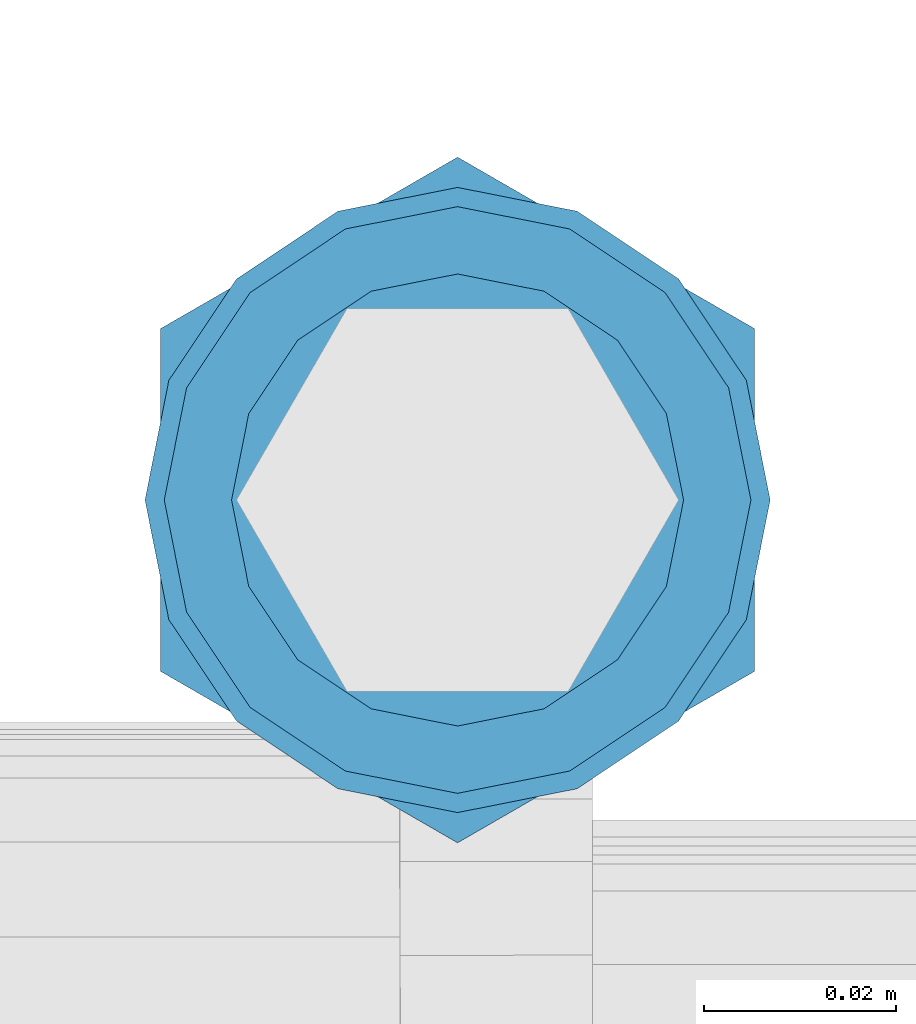
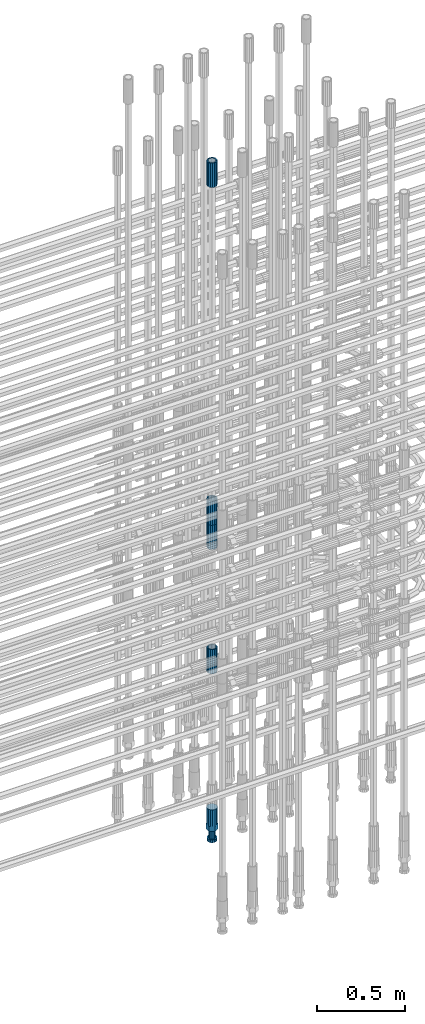
# One storey, part 16 of 119: 5 beams.
"""IFC2X3 building model written with IfcOpenShell, lengths in millimetres."""

from ifc_helpers import new_model, si_unit, frame, origin_with_axes, place, context, subcontext, project, spatial, faceted_brep, material, type_object, element, save


model = new_model("IFC2X3")

# Units and contexts
model_context = context("Model", 3, precision=1e-05, world=origin_with_axes())
body_context = subcontext(model_context, "Body", "Model", "MODEL_VIEW")
ifc_project = project(units=[si_unit("LENGTHUNIT", "METRE", prefix="MILLI"), si_unit("AREAUNIT", "SQUARE_METRE"), si_unit("VOLUMEUNIT", "CUBIC_METRE"), si_unit("MASSUNIT", "GRAM", prefix="KILO"), si_unit("TIMEUNIT", "SECOND"), si_unit("PLANEANGLEUNIT", "RADIAN"), si_unit("SOLIDANGLEUNIT", "STERADIAN"), si_unit("THERMODYNAMICTEMPERATUREUNIT", "DEGREE_CELSIUS"), si_unit("LUMINOUSINTENSITYUNIT", "LUMEN")], contexts=[model_context])

# Site, building, storey
site_placement = place(None, origin_with_axes())
site = spatial("IfcSite", under=ifc_project, at=site_placement, CompositionType="ELEMENT")
building_placement = place(site_placement, origin_with_axes())
building = spatial("IfcBuilding", under=site, at=building_placement, Name="Undefined", CompositionType="ELEMENT")
storey_placement = place(building_placement, origin_with_axes())
storey = spatial("IfcBuildingStorey", under=building, at=storey_placement, Name="Undefined", CompositionType="ELEMENT", Elevation=0.0)

# Beams
ifc_material = material(Name="STEEL/S275")
beam_type_1 = type_object("IfcBeamType", PredefinedType="NOTDEFINED")
beam_1_placement = place(storey_placement, frame((2035125.00611127, 6205269.10830108, 20704.6057291635), z_axis=(1.0, 0.0, 0.0), x_axis=(0.0, 0.0, 1.0)))
element("IfcBeam", 1, at=beam_1_placement, inside=storey, type_object=beam_type_1, material=ifc_material, Name="AG40N", context=body_context, shape_type="Brep", body=[
    faceted_brep([(1.62981450557709e-09, -23.4999999990687, 0.0), (7.45058059692383e-09, -21.7111690142192, 8.99306066057534), (170.000002125278, -21.711168999318, 8.99306066022245), (170.000002127141, -23.4999999844003, -3.66071617463604e-10), (4.65661287307739e-09, -16.6170093587134, 16.6170093578889), (170.000002122484, -16.6170093440451, 16.6170093575288), (1.86264514923096e-09, -8.99306066217832, 21.7111690140277), (170.000002118759, -8.99306064750999, 21.7111690136603), (2.3283064365387e-10, 9.31322574615479e-10, 23.5), (170.000002114102, 1.28056854009628e-08, 23.4999999996485), (-6.51925802230835e-09, 8.99306065868586, 21.7111690140241), (170.00000211224, 8.99306067335419, 21.7111690136639), (-7.45058059692383e-09, 16.6170093561523, 16.6170093578853), (170.000002109446, 16.6170093708206, 16.6170093575324), (-9.31322574615479e-09, 21.711169013055, 8.99306066057534), (170.000002108514, 21.7111690277234, 8.99306066022245), (-1.16415321826935e-09, 23.5000000009313, 0.0), (170.000002108514, 23.5000000144355, -3.66071617463604e-10), (-8.38190317153931e-09, 21.7111690151505, -8.99306066059444), (170.000002110377, 21.7111690300517, -8.9930606609546), (-5.58793544769287e-09, 16.6170093598776, -16.6170093579008), (170.000002113171, 16.6170093745459, -16.6170093582609), (-9.31322574615479e-10, 8.99306066334248, -21.7111690140396), (170.000002115965, 8.99306067801081, -21.7111690143961), (2.3283064365387e-10, 9.31322574615479e-10, -23.5), (170.00000211969, 1.7927959561348e-08, -23.5000000003843), (5.58793544769287e-09, -8.99306065752171, -21.7111690140396), (170.000002123415, -8.99306064285338, -21.7111690143961), (8.38190317153931e-09, -16.6170093549881, -16.6170093579008), (170.000002125278, -16.6170093403198, -16.6170093582646), (9.31322574615479e-09, -21.7111690121237, -8.99306066059444), (170.000002127141, -21.7111689972226, -8.9930606609546), (1.11758708953857e-08, -30.4999999990687, -9.54969436861575e-12), (1.30385160446167e-08, -28.1783257392235, -11.6718446871514), (170.000002129003, -28.1783257243223, -11.6718446875116), (170.000002129935, -30.4999999841675, -3.66071617463604e-10), (1.02445483207703e-08, -21.5667568228673, -21.5667568262129), (170.000002128072, -21.566756808199, -21.5667568265694), (7.45058059692383e-09, -11.6718446831219, -28.1783257416196), (170.000002125278, -11.6718446684536, -28.1783257419834), (3.72529029846191e-09, 3.95812094211578e-09, -30.5000000000277), (170.00000211969, 1.83936208486557e-08, -30.5000000003879), (-9.31322574615479e-10, 11.6718446905725, -28.1783257416232), (170.000002115965, 11.6718447052408, -28.1783257419797), (-6.51925802230835e-09, 21.5667568286881, -21.5667568262093), (170.000002110377, 21.5667568433564, -21.5667568265694), (-9.31322574615479e-09, 28.178325742716, -11.6718446871478), (170.000002108514, 28.1783257573843, -11.6718446875079), (-1.21071934700012e-08, 30.5, -5.91171556152403e-12), (170.000002106652, 30.5000000144355, -3.62433638656512e-10), (-1.21071934700012e-08, 28.1783257401548, 11.6718446871359), (170.00000210572, 28.1783257548232, 11.6718446867794), (-1.02445483207703e-08, 21.5667568240315, 21.5667568261974), (170.000002107583, 21.566756838467, 21.5667568258409), (-7.45058059692383e-09, 11.671844684286, 28.1783257416041), (170.000002110377, 11.6718446989544, 28.178325741244), (-2.79396772384644e-09, -2.56113708019257e-09, 30.5000000000159), (170.000002114102, 1.18743628263474e-08, 30.4999999996558), (1.86264514923096e-09, -11.6718446896411, 28.1783257416114), (170.000002118759, -11.67184467474, 28.178325741244), (7.45058059692383e-09, -21.5667568275239, 21.5667568261974), (170.000002123415, -21.5667568126228, 21.5667568258373), (1.02445483207703e-08, -28.1783257415518, 11.6718446871359), (170.000002127141, -28.1783257271163, 11.6718446867794)], [[[0, 1, 2, 3]], [[1, 4, 5, 2]], [[4, 6, 7, 5]], [[6, 8, 9, 7]], [[8, 10, 11, 9]], [[10, 12, 13, 11]], [[12, 14, 15, 13]], [[14, 16, 17, 15]], [[16, 18, 19, 17]], [[18, 20, 21, 19]], [[20, 22, 23, 21]], [[22, 24, 25, 23]], [[24, 26, 27, 25]], [[26, 28, 29, 27]], [[28, 30, 31, 29]], [[30, 0, 3, 31]], [[32, 33, 34, 35]], [[33, 36, 37, 34]], [[36, 38, 39, 37]], [[38, 40, 41, 39]], [[40, 42, 43, 41]], [[42, 44, 45, 43]], [[44, 46, 47, 45]], [[46, 48, 49, 47]], [[48, 50, 51, 49]], [[50, 52, 53, 51]], [[52, 54, 55, 53]], [[54, 56, 57, 55]], [[56, 58, 59, 57]], [[58, 60, 61, 59]], [[60, 62, 63, 61]], [[62, 32, 35, 63]], [[37, 39, 41, 43, 45, 47, 49, 51, 53, 55, 57, 59, 61, 63, 35, 34], [5, 7, 9, 11, 13, 15, 17, 19, 21, 23, 25, 27, 29, 31, 3, 2]], [[62, 60, 58, 56, 54, 52, 50, 48, 46, 44, 42, 40, 38, 36, 33, 32], [30, 28, 26, 24, 22, 20, 18, 16, 14, 12, 10, 8, 6, 4, 1, 0]]]),
])
beam_2_placement = place(storey_placement, frame((2035125.00611127, 6205269.10830108, 20007.7168583144), z_axis=(-0.99999999999998, 1.98000110685822e-07, 0.0), x_axis=(0.0, 0.0, -1.0)))
element("IfcBeam", 2, at=beam_2_placement, inside=storey, type_object=beam_type_1, material=ifc_material, Name="AG40N", context=body_context, shape_type="Brep", body=[
    faceted_brep([(1.62981450557709e-09, -23.4999999990687, 0.0), (7.45058059692383e-09, -21.7111690142192, 8.99306066057534), (170.000002125278, -21.711168999318, 8.99306066022245), (170.000002127141, -23.4999999844003, -3.66071617463604e-10), (4.65661287307739e-09, -16.6170093587134, 16.6170093578889), (170.000002122484, -16.6170093440451, 16.6170093575288), (1.86264514923096e-09, -8.99306066217832, 21.7111690140277), (170.000002118759, -8.99306064750999, 21.7111690136603), (2.3283064365387e-10, 9.31322574615479e-10, 23.5), (170.000002114102, 1.28056854009628e-08, 23.4999999996485), (-6.51925802230835e-09, 8.99306065868586, 21.7111690140241), (170.00000211224, 8.99306067335419, 21.7111690136639), (-7.45058059692383e-09, 16.6170093561523, 16.6170093578853), (170.000002109446, 16.6170093708206, 16.6170093575324), (-9.31322574615479e-09, 21.711169013055, 8.99306066057534), (170.000002108514, 21.7111690277234, 8.99306066022245), (-1.16415321826935e-09, 23.5000000009313, 0.0), (170.000002108514, 23.5000000144355, -3.66071617463604e-10), (-8.38190317153931e-09, 21.7111690151505, -8.99306066059444), (170.000002110377, 21.7111690300517, -8.9930606609546), (-5.58793544769287e-09, 16.6170093598776, -16.6170093579008), (170.000002113171, 16.6170093745459, -16.6170093582609), (-9.31322574615479e-10, 8.99306066334248, -21.7111690140396), (170.000002115965, 8.99306067801081, -21.7111690143961), (2.3283064365387e-10, 9.31322574615479e-10, -23.5), (170.00000211969, 1.7927959561348e-08, -23.5000000003843), (5.58793544769287e-09, -8.99306065752171, -21.7111690140396), (170.000002123415, -8.99306064285338, -21.7111690143961), (8.38190317153931e-09, -16.6170093549881, -16.6170093579008), (170.000002125278, -16.6170093403198, -16.6170093582646), (9.31322574615479e-09, -21.7111690121237, -8.99306066059444), (170.000002127141, -21.7111689972226, -8.9930606609546), (1.11758708953857e-08, -30.4999999990687, -9.54969436861575e-12), (1.30385160446167e-08, -28.1783257392235, -11.6718446871514), (170.000002129003, -28.1783257243223, -11.6718446875116), (170.000002129935, -30.4999999841675, -3.66071617463604e-10), (1.02445483207703e-08, -21.5667568228673, -21.5667568262129), (170.000002128072, -21.566756808199, -21.5667568265694), (7.45058059692383e-09, -11.6718446831219, -28.1783257416196), (170.000002125278, -11.6718446684536, -28.1783257419834), (3.72529029846191e-09, 3.95812094211578e-09, -30.5000000000277), (170.00000211969, 1.83936208486557e-08, -30.5000000003879), (-9.31322574615479e-10, 11.6718446905725, -28.1783257416232), (170.000002115965, 11.6718447052408, -28.1783257419797), (-6.51925802230835e-09, 21.5667568286881, -21.5667568262093), (170.000002110377, 21.5667568433564, -21.5667568265694), (-9.31322574615479e-09, 28.178325742716, -11.6718446871478), (170.000002108514, 28.1783257573843, -11.6718446875079), (-1.21071934700012e-08, 30.5, -5.91171556152403e-12), (170.000002106652, 30.5000000144355, -3.62433638656512e-10), (-1.21071934700012e-08, 28.1783257401548, 11.6718446871359), (170.00000210572, 28.1783257548232, 11.6718446867794), (-1.02445483207703e-08, 21.5667568240315, 21.5667568261974), (170.000002107583, 21.566756838467, 21.5667568258409), (-7.45058059692383e-09, 11.671844684286, 28.1783257416041), (170.000002110377, 11.6718446989544, 28.178325741244), (-2.79396772384644e-09, -2.56113708019257e-09, 30.5000000000159), (170.000002114102, 1.18743628263474e-08, 30.4999999996558), (1.86264514923096e-09, -11.6718446896411, 28.1783257416114), (170.000002118759, -11.67184467474, 28.178325741244), (7.45058059692383e-09, -21.5667568275239, 21.5667568261974), (170.000002123415, -21.5667568126228, 21.5667568258373), (1.02445483207703e-08, -28.1783257415518, 11.6718446871359), (170.000002127141, -28.1783257271163, 11.6718446867794)], [[[0, 1, 2, 3]], [[1, 4, 5, 2]], [[4, 6, 7, 5]], [[6, 8, 9, 7]], [[8, 10, 11, 9]], [[10, 12, 13, 11]], [[12, 14, 15, 13]], [[14, 16, 17, 15]], [[16, 18, 19, 17]], [[18, 20, 21, 19]], [[20, 22, 23, 21]], [[22, 24, 25, 23]], [[24, 26, 27, 25]], [[26, 28, 29, 27]], [[28, 30, 31, 29]], [[30, 0, 3, 31]], [[32, 33, 34, 35]], [[33, 36, 37, 34]], [[36, 38, 39, 37]], [[38, 40, 41, 39]], [[40, 42, 43, 41]], [[42, 44, 45, 43]], [[44, 46, 47, 45]], [[46, 48, 49, 47]], [[48, 50, 51, 49]], [[50, 52, 53, 51]], [[52, 54, 55, 53]], [[54, 56, 57, 55]], [[56, 58, 59, 57]], [[58, 60, 61, 59]], [[60, 62, 63, 61]], [[62, 32, 35, 63]], [[37, 39, 41, 43, 45, 47, 49, 51, 53, 55, 57, 59, 61, 63, 35, 34], [5, 7, 9, 11, 13, 15, 17, 19, 21, 23, 25, 27, 29, 31, 3, 2]], [[62, 60, 58, 56, 54, 52, 50, 48, 46, 44, 42, 40, 38, 36, 33, 32], [30, 28, 26, 24, 22, 20, 18, 16, 14, 12, 10, 8, 6, 4, 1, 0]]]),
])
beam_3_placement = place(storey_placement, frame((2035125.00611127, 6205269.10830108, 23229.9857291635), z_axis=(1.0, 0.0, 0.0), x_axis=(0.0, 0.0, 1.0)))
element("IfcBeam", 3, at=beam_3_placement, inside=storey, type_object=beam_type_1, material=ifc_material, Name="AG40N", context=body_context, shape_type="Brep", body=[
    faceted_brep([(1.62981450557709e-09, -23.4999999990687, 0.0), (7.45058059692383e-09, -21.7111690142192, 8.99306066057534), (170.000002125278, -21.711168999318, 8.99306066022245), (170.000002127141, -23.4999999844003, -3.66071617463604e-10), (4.65661287307739e-09, -16.6170093587134, 16.6170093578889), (170.000002122484, -16.6170093440451, 16.6170093575288), (1.86264514923096e-09, -8.99306066217832, 21.7111690140277), (170.000002118759, -8.99306064750999, 21.7111690136603), (2.3283064365387e-10, 9.31322574615479e-10, 23.5), (170.000002114102, 1.28056854009628e-08, 23.4999999996485), (-6.51925802230835e-09, 8.99306065868586, 21.7111690140241), (170.00000211224, 8.99306067335419, 21.7111690136639), (-7.45058059692383e-09, 16.6170093561523, 16.6170093578853), (170.000002109446, 16.6170093708206, 16.6170093575324), (-9.31322574615479e-09, 21.711169013055, 8.99306066057534), (170.000002108514, 21.7111690277234, 8.99306066022245), (-1.16415321826935e-09, 23.5000000009313, 0.0), (170.000002108514, 23.5000000144355, -3.66071617463604e-10), (-8.38190317153931e-09, 21.7111690151505, -8.99306066059444), (170.000002110377, 21.7111690300517, -8.9930606609546), (-5.58793544769287e-09, 16.6170093598776, -16.6170093579008), (170.000002113171, 16.6170093745459, -16.6170093582609), (-9.31322574615479e-10, 8.99306066334248, -21.7111690140396), (170.000002115965, 8.99306067801081, -21.7111690143961), (2.3283064365387e-10, 9.31322574615479e-10, -23.5), (170.00000211969, 1.7927959561348e-08, -23.5000000003843), (5.58793544769287e-09, -8.99306065752171, -21.7111690140396), (170.000002123415, -8.99306064285338, -21.7111690143961), (8.38190317153931e-09, -16.6170093549881, -16.6170093579008), (170.000002125278, -16.6170093403198, -16.6170093582646), (9.31322574615479e-09, -21.7111690121237, -8.99306066059444), (170.000002127141, -21.7111689972226, -8.9930606609546), (1.11758708953857e-08, -30.4999999990687, -9.54969436861575e-12), (1.30385160446167e-08, -28.1783257392235, -11.6718446871514), (170.000002129003, -28.1783257243223, -11.6718446875116), (170.000002129935, -30.4999999841675, -3.66071617463604e-10), (1.02445483207703e-08, -21.5667568228673, -21.5667568262129), (170.000002128072, -21.566756808199, -21.5667568265694), (7.45058059692383e-09, -11.6718446831219, -28.1783257416196), (170.000002125278, -11.6718446684536, -28.1783257419834), (3.72529029846191e-09, 3.95812094211578e-09, -30.5000000000277), (170.00000211969, 1.83936208486557e-08, -30.5000000003879), (-9.31322574615479e-10, 11.6718446905725, -28.1783257416232), (170.000002115965, 11.6718447052408, -28.1783257419797), (-6.51925802230835e-09, 21.5667568286881, -21.5667568262093), (170.000002110377, 21.5667568433564, -21.5667568265694), (-9.31322574615479e-09, 28.178325742716, -11.6718446871478), (170.000002108514, 28.1783257573843, -11.6718446875079), (-1.21071934700012e-08, 30.5, -5.91171556152403e-12), (170.000002106652, 30.5000000144355, -3.62433638656512e-10), (-1.21071934700012e-08, 28.1783257401548, 11.6718446871359), (170.00000210572, 28.1783257548232, 11.6718446867794), (-1.02445483207703e-08, 21.5667568240315, 21.5667568261974), (170.000002107583, 21.566756838467, 21.5667568258409), (-7.45058059692383e-09, 11.671844684286, 28.1783257416041), (170.000002110377, 11.6718446989544, 28.178325741244), (-2.79396772384644e-09, -2.56113708019257e-09, 30.5000000000159), (170.000002114102, 1.18743628263474e-08, 30.4999999996558), (1.86264514923096e-09, -11.6718446896411, 28.1783257416114), (170.000002118759, -11.67184467474, 28.178325741244), (7.45058059692383e-09, -21.5667568275239, 21.5667568261974), (170.000002123415, -21.5667568126228, 21.5667568258373), (1.02445483207703e-08, -28.1783257415518, 11.6718446871359), (170.000002127141, -28.1783257271163, 11.6718446867794)], [[[0, 1, 2, 3]], [[1, 4, 5, 2]], [[4, 6, 7, 5]], [[6, 8, 9, 7]], [[8, 10, 11, 9]], [[10, 12, 13, 11]], [[12, 14, 15, 13]], [[14, 16, 17, 15]], [[16, 18, 19, 17]], [[18, 20, 21, 19]], [[20, 22, 23, 21]], [[22, 24, 25, 23]], [[24, 26, 27, 25]], [[26, 28, 29, 27]], [[28, 30, 31, 29]], [[30, 0, 3, 31]], [[32, 33, 34, 35]], [[33, 36, 37, 34]], [[36, 38, 39, 37]], [[38, 40, 41, 39]], [[40, 42, 43, 41]], [[42, 44, 45, 43]], [[44, 46, 47, 45]], [[46, 48, 49, 47]], [[48, 50, 51, 49]], [[50, 52, 53, 51]], [[52, 54, 55, 53]], [[54, 56, 57, 55]], [[56, 58, 59, 57]], [[58, 60, 61, 59]], [[60, 62, 63, 61]], [[62, 32, 35, 63]], [[37, 39, 41, 43, 45, 47, 49, 51, 53, 55, 57, 59, 61, 63, 35, 34], [5, 7, 9, 11, 13, 15, 17, 19, 21, 23, 25, 27, 29, 31, 3, 2]], [[62, 60, 58, 56, 54, 52, 50, 48, 46, 44, 42, 40, 38, 36, 33, 32], [30, 28, 26, 24, 22, 20, 18, 16, 14, 12, 10, 8, 6, 4, 1, 0]]]),
])
beam_4_placement = place(storey_placement, frame((2035125.00611127, 6205269.10830108, 21044.6068583137), z_axis=(-0.99999999999998, 1.98000110685822e-07, 0.0), x_axis=(0.0, 0.0, -1.0)))
element("IfcBeam", 4, at=beam_4_placement, inside=storey, type_object=beam_type_1, material=ifc_material, Name="AG40N", context=body_context, shape_type="Brep", body=[
    faceted_brep([(1.62981450557709e-09, -23.4999999990687, 0.0), (7.45058059692383e-09, -21.7111690142192, 8.99306066057534), (170.000002125278, -21.711168999318, 8.99306066022245), (170.000002127141, -23.4999999844003, -3.66071617463604e-10), (4.65661287307739e-09, -16.6170093587134, 16.6170093578889), (170.000002122484, -16.6170093440451, 16.6170093575288), (1.86264514923096e-09, -8.99306066217832, 21.7111690140277), (170.000002118759, -8.99306064750999, 21.7111690136603), (2.3283064365387e-10, 9.31322574615479e-10, 23.5), (170.000002114102, 1.28056854009628e-08, 23.4999999996485), (-6.51925802230835e-09, 8.99306065868586, 21.7111690140241), (170.00000211224, 8.99306067335419, 21.7111690136639), (-7.45058059692383e-09, 16.6170093561523, 16.6170093578853), (170.000002109446, 16.6170093708206, 16.6170093575324), (-9.31322574615479e-09, 21.711169013055, 8.99306066057534), (170.000002108514, 21.7111690277234, 8.99306066022245), (-1.16415321826935e-09, 23.5000000009313, 0.0), (170.000002108514, 23.5000000144355, -3.66071617463604e-10), (-8.38190317153931e-09, 21.7111690151505, -8.99306066059444), (170.000002110377, 21.7111690300517, -8.9930606609546), (-5.58793544769287e-09, 16.6170093598776, -16.6170093579008), (170.000002113171, 16.6170093745459, -16.6170093582609), (-9.31322574615479e-10, 8.99306066334248, -21.7111690140396), (170.000002115965, 8.99306067801081, -21.7111690143961), (2.3283064365387e-10, 9.31322574615479e-10, -23.5), (170.00000211969, 1.7927959561348e-08, -23.5000000003843), (5.58793544769287e-09, -8.99306065752171, -21.7111690140396), (170.000002123415, -8.99306064285338, -21.7111690143961), (8.38190317153931e-09, -16.6170093549881, -16.6170093579008), (170.000002125278, -16.6170093403198, -16.6170093582646), (9.31322574615479e-09, -21.7111690121237, -8.99306066059444), (170.000002127141, -21.7111689972226, -8.9930606609546), (1.11758708953857e-08, -30.4999999990687, -9.54969436861575e-12), (1.30385160446167e-08, -28.1783257392235, -11.6718446871514), (170.000002129003, -28.1783257243223, -11.6718446875116), (170.000002129935, -30.4999999841675, -3.66071617463604e-10), (1.02445483207703e-08, -21.5667568228673, -21.5667568262129), (170.000002128072, -21.566756808199, -21.5667568265694), (7.45058059692383e-09, -11.6718446831219, -28.1783257416196), (170.000002125278, -11.6718446684536, -28.1783257419834), (3.72529029846191e-09, 3.95812094211578e-09, -30.5000000000277), (170.00000211969, 1.83936208486557e-08, -30.5000000003879), (-9.31322574615479e-10, 11.6718446905725, -28.1783257416232), (170.000002115965, 11.6718447052408, -28.1783257419797), (-6.51925802230835e-09, 21.5667568286881, -21.5667568262093), (170.000002110377, 21.5667568433564, -21.5667568265694), (-9.31322574615479e-09, 28.178325742716, -11.6718446871478), (170.000002108514, 28.1783257573843, -11.6718446875079), (-1.21071934700012e-08, 30.5, -5.91171556152403e-12), (170.000002106652, 30.5000000144355, -3.62433638656512e-10), (-1.21071934700012e-08, 28.1783257401548, 11.6718446871359), (170.00000210572, 28.1783257548232, 11.6718446867794), (-1.02445483207703e-08, 21.5667568240315, 21.5667568261974), (170.000002107583, 21.566756838467, 21.5667568258409), (-7.45058059692383e-09, 11.671844684286, 28.1783257416041), (170.000002110377, 11.6718446989544, 28.178325741244), (-2.79396772384644e-09, -2.56113708019257e-09, 30.5000000000159), (170.000002114102, 1.18743628263474e-08, 30.4999999996558), (1.86264514923096e-09, -11.6718446896411, 28.1783257416114), (170.000002118759, -11.67184467474, 28.178325741244), (7.45058059692383e-09, -21.5667568275239, 21.5667568261974), (170.000002123415, -21.5667568126228, 21.5667568258373), (1.02445483207703e-08, -28.1783257415518, 11.6718446871359), (170.000002127141, -28.1783257271163, 11.6718446867794)], [[[0, 1, 2, 3]], [[1, 4, 5, 2]], [[4, 6, 7, 5]], [[6, 8, 9, 7]], [[8, 10, 11, 9]], [[10, 12, 13, 11]], [[12, 14, 15, 13]], [[14, 16, 17, 15]], [[16, 18, 19, 17]], [[18, 20, 21, 19]], [[20, 22, 23, 21]], [[22, 24, 25, 23]], [[24, 26, 27, 25]], [[26, 28, 29, 27]], [[28, 30, 31, 29]], [[30, 0, 3, 31]], [[32, 33, 34, 35]], [[33, 36, 37, 34]], [[36, 38, 39, 37]], [[38, 40, 41, 39]], [[40, 42, 43, 41]], [[42, 44, 45, 43]], [[44, 46, 47, 45]], [[46, 48, 49, 47]], [[48, 50, 51, 49]], [[50, 52, 53, 51]], [[52, 54, 55, 53]], [[54, 56, 57, 55]], [[56, 58, 59, 57]], [[58, 60, 61, 59]], [[60, 62, 63, 61]], [[62, 32, 35, 63]], [[37, 39, 41, 43, 45, 47, 49, 51, 53, 55, 57, 59, 61, 63, 35, 34], [5, 7, 9, 11, 13, 15, 17, 19, 21, 23, 25, 27, 29, 31, 3, 2]], [[62, 60, 58, 56, 54, 52, 50, 48, 46, 44, 42, 40, 38, 36, 33, 32], [30, 28, 26, 24, 22, 20, 18, 16, 14, 12, 10, 8, 6, 4, 1, 0]]]),
])
beam_type_2 = type_object("IfcBeamType", Name="ROD65", PredefinedType="NOTDEFINED")
beam_5_placement = place(storey_placement, frame((2035125.00611127, 6205269.10830108, 18890.9568583144), z_axis=(-0.99999999999998, 1.98000110685822e-07, 0.0), x_axis=(0.0, 0.0, -1.0)))
element("IfcBeam", 5, at=beam_5_placement, inside=storey, type_object=beam_type_2, material=ifc_material, Name="AGB40", ObjectType="ROD65", context=body_context, shape_type="Brep", body=[
    faceted_brep([(116.999999999069, 17.8249999252148, 30.8738056446964), (116.999999998137, 22.0056957420893, 23.632628078838), (116.999999999069, 12.4372115600854, 30.0260848066173), (116.999999999069, 8.17543111252598, 30.8738056446964), (117.000000000931, -17.8250000746921, 30.8738056446964), (150.200000001118, -17.8250000723638, 30.8738056446964), (150.199999999255, 17.8249999275431, 30.8738056446964), (117.000000000931, -8.17543109622784, 30.8738056446964), (117.000000001863, -22.0056959956419, 23.6326278985034), (117.000000000931, -12.4372115437873, 30.0260848066173), (117.000000001863, -35.6500000746455, -2.18278728425503e-10), (150.200000002049, -35.6500000723172, -2.18278728425503e-10), (117.000000001863, -30.8443149488885, 8.32369080289209), (117.000000001863, -30.8443149488885, -8.32369080355784), (117.000000002794, -32.4999999918509, 0.0), (117.000000000931, -17.8250000746921, -30.873805645133), (150.200000001118, -17.8250000723638, -30.873805645133), (117.000000001863, -22.0056959961075, -23.6326278982269), (117.000000000931, -8.17543109389953, -30.873805645133), (117.000000000931, -12.4372115437873, -30.0260848066173), (116.999999999069, 17.8249999252148, -30.873805645133), (150.199999999255, 17.8249999275431, -30.873805645133), (116.999999999069, 8.17543111019768, -30.873805645133), (116.999999999069, 12.4372115600854, -30.0260848066173), (116.999999998137, 22.005695742555, -23.6326280785652), (116.999999998137, 35.6499999251682, -2.18278728425503e-10), (150.199999998324, 35.6499999277294, -2.18278728425503e-10), (116.999999998137, 30.8443150522653, -8.32369036550881), (116.999999997206, 32.5000000081491, 0.0), (116.999999998137, 30.8443150522653, 8.32369036483942), (1.86264514923096e-09, -22.9809703885112, 22.9809703885621), (1.86264514923096e-09, -30.0260848065373, 12.4372115518672), (117.000000001863, -30.0260847983882, 12.4372115518672), (117.000000001863, -22.9809703803621, 22.9809703885621), (-1.86264514923096e-09, 22.9809703885112, -22.9809703885621), (-1.86264514923096e-09, 30.0260848065373, -12.4372115518672), (116.999999998137, 30.0260848146863, -12.4372115518672), (116.999999998137, 22.9809703966603, -22.9809703885621), (1.86264514923096e-09, -30.0260848065373, -12.4372115518672), (1.86264514923096e-09, -22.9809703885112, -22.9809703885621), (117.000000001863, -22.9809703803621, -22.9809703885621), (117.000000001863, -30.0260847983882, -12.4372115518672), (9.31322574615479e-10, -12.4372115519363, 30.0260848066173), (0.0, 0.0, 32.5), (-9.31322574615479e-10, 12.4372115519363, 30.0260848066173), (-1.86264514923096e-09, 22.9809703885112, 22.9809703885621), (-1.86264514923096e-09, 30.0260848065373, 12.4372115518672), (-2.79396772384644e-09, 32.5, 0.0), (-9.31322574615479e-10, 12.4372115519363, -30.0260848066173), (0.0, 0.0, -32.5), (9.31322574615479e-10, -12.4372115519363, -30.0260848066173), (2.79396772384644e-09, -32.5, 0.0), (116.999999998137, 22.9809703966603, 22.9809703885621), (116.999999998137, 30.0260848146863, 12.4372115518672), (117.0, 8.14907252788544e-09, -32.5), (117.0, 8.14907252788544e-09, 32.5), (150.200000000186, -10.5000000959262, 18.1865334791873), (150.199999999255, -9.59262251853943e-08, 20.9999999997126), (150.199999998324, 10.4999999040738, 18.1865334791873), (150.199999997392, 18.1865333835594, 10.4999999997126), (150.199999997392, 20.9999999040738, -2.87400325760245e-10), (150.199999997392, 18.1865333835594, -10.5000000002874), (150.199999998324, 10.4999999040738, -18.1865334797621), (150.199999999255, -9.59262251853943e-08, -21.0000000002874), (150.200000000186, -10.5000000959262, -18.1865334797621), (150.200000000186, -18.1865335754119, -10.5000000002874), (150.200000001118, -21.0000000959262, -2.87400325760245e-10), (150.200000000186, -18.1865335754119, 10.4999999997126), (210.979999999516, 10.4999999082647, 18.1865334791873), (210.979999999516, -9.17352735996246e-08, 20.9999999997126), (210.979999997653, 18.1865333877504, 10.4999999997126), (210.979999997653, 20.9999999082647, -2.87400325760245e-10), (210.979999997653, 18.1865333877504, -10.5000000002874), (210.979999999516, 10.4999999082647, -18.1865334797621), (210.979999999516, -9.17352735996246e-08, -21.0000000002874), (210.979999999516, -10.5000000917353, -18.1865334797621), (210.980000000447, -18.1865335712209, -10.5000000002874), (210.980000001378, -21.0000000917353, -2.87400325760245e-10), (210.980000000447, -18.1865335712209, 10.4999999997126), (210.979999999516, -10.5000000917353, 18.1865334791873), (211.001368402503, -27.7269939335529, -11.4911163272045), (211.003082515672, -21.2238095656503, -21.2238154190527), (231.002518340945, -21.2131946226582, -21.2132004554769), (231.000804228708, -27.7163789905608, -11.4805013636287), (211.001368415542, -11.4911086384673, -27.7269970399575), (231.000804241747, -11.4804936954752, -27.7163820763781), (210.996487061493, -0.0106066407170147, -30.0106107396168), (230.995922887698, 8.30227509140968e-06, -29.999995776041), (210.98918159306, 11.4698940692469, -27.7269970332745), (230.988617419265, 11.4805090120062, -27.7163820696951), (210.980564201251, 21.2025913291145, -21.2238154067054), (230.980000027455, 21.2132062721066, -21.2132004431296), (210.971946807578, 27.7057702087332, -11.4911163110701), (230.971382633783, 27.7163851517253, -11.4805013474943), (210.964641331695, 29.9893806746695, -0.0106149565435771), (230.9640771579, 29.9999956176616, 7.03221303410828e-09), (210.959759964608, 27.7057637346443, 11.4698863966551), (230.959195790812, 27.7163786776364, 11.4805013602345), (210.958045851439, 21.2025793667417, 21.2025854885032), (230.957481677644, 21.2131943097338, 21.2132004520827), (210.959759951569, 11.4698784395587, 27.705767109408), (230.959195776843, 11.4804933823179, 27.7163820729838), (210.964641305618, -0.0106235581915826, 29.9893808090674), (230.964077131823, -8.61519947648048e-06, 29.9999957726432), (210.971946774051, -11.4911242681555, 27.7057671027251), (230.971382599324, -11.4805093251634, 27.7163820663009), (210.98056416586, -21.2238215280231, 21.2025854761559), (230.979999991134, -21.2132065852638, 21.2132004397354), (210.989181559533, -27.7270004076418, 11.4698863805206), (230.988617384806, -27.7163854646496, 11.4805013441), (210.996487035416, -30.0106108735781, -0.0106149740058754), (230.995922861621, -29.999995930586, -1.04300852399319e-08)], [[[0, 1, 2, 3]], [[4, 5, 6, 0, 3, 7]], [[8, 4, 7, 9]], [[10, 11, 5, 4, 8, 12]], [[13, 10, 12, 14]], [[15, 16, 11, 10, 13, 17]], [[18, 15, 17, 19]], [[20, 21, 16, 15, 18, 22]], [[20, 22, 23, 24]], [[25, 26, 21, 20, 24, 27]], [[25, 27, 28, 29]], [[30, 31, 32, 33]], [[34, 35, 36, 37]], [[38, 39, 40, 41]], [[31, 30, 42, 43, 44, 45, 46, 47, 35, 34, 48, 49, 50, 39, 38, 51]], [[46, 45, 52, 53]], [[28, 47, 46, 53, 29]], [[27, 36, 35, 47, 28]], [[24, 37, 36, 27]], [[23, 48, 34, 37, 24]], [[22, 54, 49, 48, 23]], [[18, 54, 22]], [[19, 50, 49, 54, 18]], [[17, 40, 39, 50, 19]], [[13, 41, 40, 17]], [[14, 51, 38, 41, 13]], [[12, 32, 31, 51, 14]], [[8, 33, 32, 12]], [[9, 42, 30, 33, 8]], [[7, 55, 43, 42, 9]], [[3, 55, 7]], [[2, 44, 43, 55, 3]], [[1, 52, 45, 44, 2]], [[29, 53, 52, 1]], [[0, 6, 26, 25, 29, 1]], [[5, 11, 16, 21, 26, 6], [56, 57, 58, 59, 60, 61, 62, 63, 64, 65, 66, 67]], [[68, 58, 57, 69]], [[70, 59, 58, 68]], [[71, 60, 59, 70]], [[72, 61, 60, 71]], [[73, 62, 61, 72]], [[74, 63, 62, 73]], [[75, 64, 63, 74]], [[76, 65, 64, 75]], [[77, 66, 65, 76]], [[78, 67, 66, 77]], [[79, 56, 67, 78]], [[69, 57, 56, 79]], [[80, 81, 82, 83]], [[81, 84, 85, 82]], [[84, 86, 87, 85]], [[86, 88, 89, 87]], [[88, 90, 91, 89]], [[90, 92, 93, 91]], [[92, 94, 95, 93]], [[94, 96, 97, 95]], [[96, 98, 99, 97]], [[98, 100, 101, 99]], [[100, 102, 103, 101]], [[102, 104, 105, 103]], [[104, 106, 107, 105]], [[106, 108, 109, 107]], [[108, 110, 111, 109]], [[82, 85, 87, 89, 91, 93, 95, 97, 99, 101, 103, 105, 107, 109, 111, 83]], [[110, 80, 83, 111]], [[108, 106, 104, 102, 100, 98, 96, 94, 92, 90, 88, 86, 84, 81, 80, 110], [78, 77, 76, 75, 74, 73, 72, 71, 70, 68, 69, 79]]]),
])

save(model, "model.ifc")
